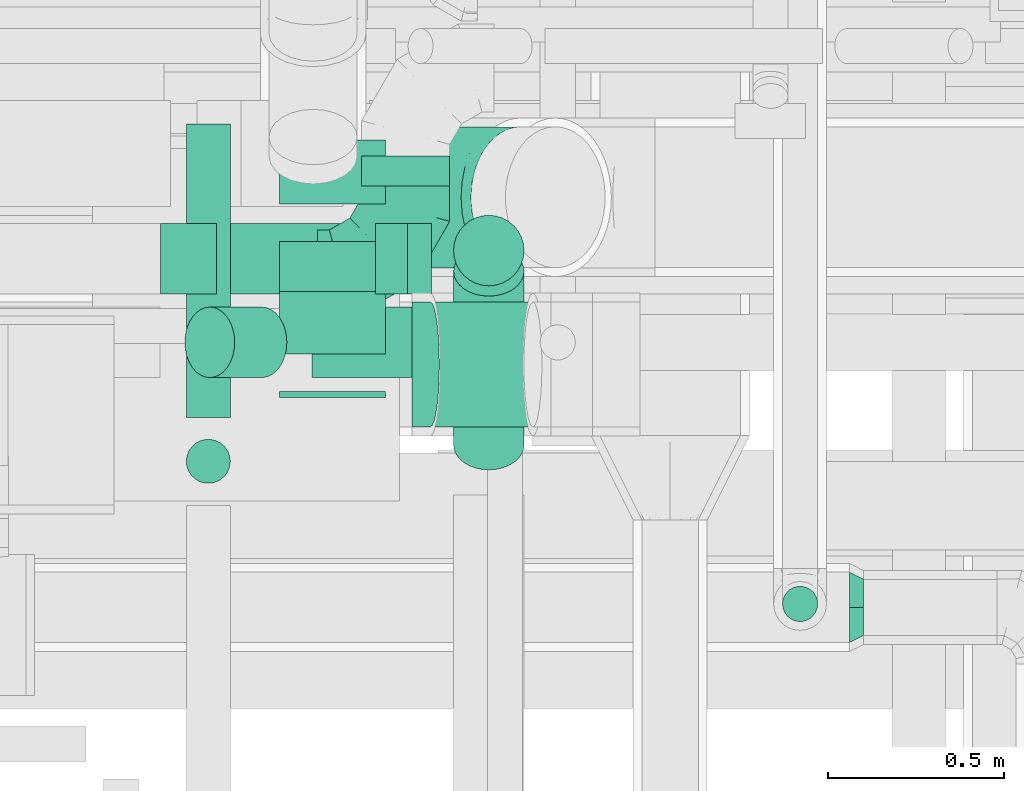
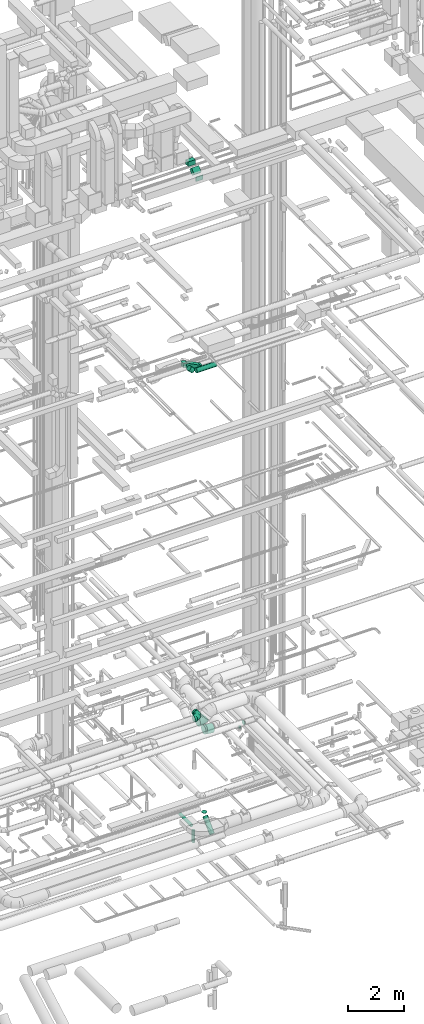
# One storey, part 253 of 337: 13 flow segments, 6 flow fittings.
"""IFC2X3 building model written with IfcOpenShell, lengths in millimetres."""

from ifc_helpers import new_model, entity, si_unit, converted_unit, derived_unit, direction, frame, frame_2d, origin, origin_2d_with_axis, place, context, subcontext, project, spatial, polyline, circle_curve, parameter, trimmed, segment, composite_curve, rectangle, circle, outline, extrude, faceted_brep, source, transform, mapped, material, type_object, type_shapes, element, save


model = new_model("IFC2X3")

# Units and contexts
model_context = context("Model", 3, precision=0.01, world=origin(), true_north=direction((6.12303176911189e-17, 1.0)))
body_context = subcontext(model_context, "Body", "Model", "MODEL_VIEW")
ifc_project = project(units=[si_unit("LENGTHUNIT", "METRE", prefix="MILLI"), si_unit("AREAUNIT", "SQUARE_METRE"), si_unit("VOLUMEUNIT", "CUBIC_METRE"), converted_unit("PLANEANGLEUNIT", "DEGREE", entity("IfcRatioMeasure", 0.0174532925199433), si_unit("PLANEANGLEUNIT", "RADIAN"), dimensions=[0, 0, 0, 0, 0, 0, 0]), si_unit("MASSUNIT", "GRAM", prefix="KILO"), derived_unit("MASSDENSITYUNIT", [(si_unit("MASSUNIT", "GRAM", prefix="KILO"), 1), (si_unit("LENGTHUNIT", "METRE"), -3)]), derived_unit("MOMENTOFINERTIAUNIT", [(si_unit("LENGTHUNIT", "METRE"), 4)]), si_unit("TIMEUNIT", "SECOND"), si_unit("FREQUENCYUNIT", "HERTZ"), si_unit("THERMODYNAMICTEMPERATUREUNIT", "DEGREE_CELSIUS"), derived_unit("THERMALTRANSMITTANCEUNIT", [(si_unit("MASSUNIT", "GRAM", prefix="KILO"), 1), (si_unit("THERMODYNAMICTEMPERATUREUNIT", "KELVIN"), -1), (si_unit("TIMEUNIT", "SECOND"), -3)]), derived_unit("VOLUMETRICFLOWRATEUNIT", [(si_unit("LENGTHUNIT", "METRE"), 3), (si_unit("TIMEUNIT", "SECOND"), -1)]), derived_unit("MASSFLOWRATEUNIT", [(si_unit("MASSUNIT", "GRAM", prefix="KILO"), 1), (si_unit("TIMEUNIT", "SECOND"), -1)]), derived_unit("ROTATIONALFREQUENCYUNIT", [(si_unit("TIMEUNIT", "SECOND"), -1)]), si_unit("ELECTRICCURRENTUNIT", "AMPERE"), si_unit("ELECTRICVOLTAGEUNIT", "VOLT"), si_unit("POWERUNIT", "WATT"), si_unit("FORCEUNIT", "NEWTON", prefix="KILO"), si_unit("ILLUMINANCEUNIT", "LUX"), si_unit("LUMINOUSFLUXUNIT", "LUMEN"), si_unit("LUMINOUSINTENSITYUNIT", "CANDELA"), derived_unit("USERDEFINED", [(si_unit("MASSUNIT", "GRAM", prefix="KILO"), -1), (si_unit("LENGTHUNIT", "METRE"), -2), (si_unit("TIMEUNIT", "SECOND"), 3), (si_unit("LUMINOUSFLUXUNIT", "LUMEN"), 1)]), derived_unit("LINEARVELOCITYUNIT", [(si_unit("LENGTHUNIT", "METRE"), 1), (si_unit("TIMEUNIT", "SECOND"), -1)]), si_unit("PRESSUREUNIT", "PASCAL"), derived_unit("USERDEFINED", [(si_unit("LENGTHUNIT", "METRE"), -2), (si_unit("MASSUNIT", "GRAM", prefix="KILO"), 1), (si_unit("TIMEUNIT", "SECOND"), -2)]), derived_unit("LINEARFORCEUNIT", [(si_unit("MASSUNIT", "GRAM", prefix="KILO"), 1), (si_unit("LENGTHUNIT", "METRE"), 1), (si_unit("TIMEUNIT", "SECOND"), -2), (si_unit("LENGTHUNIT", "METRE"), -1)]), derived_unit("PLANARFORCEUNIT", [(si_unit("MASSUNIT", "GRAM", prefix="KILO"), 1), (si_unit("LENGTHUNIT", "METRE"), 1), (si_unit("TIMEUNIT", "SECOND"), -2), (si_unit("LENGTHUNIT", "METRE"), -2)])], contexts=[model_context])

# Site, building, storey
site_placement = place(None, origin())
site = spatial("IfcSite", under=ifc_project, at=site_placement, CompositionType="ELEMENT")
building_placement = place(site_placement, origin())
building = spatial("IfcBuilding", under=site, at=building_placement, CompositionType="ELEMENT")
storey_placement = place(building_placement, origin())
storey = spatial("IfcBuildingStorey", under=building, at=storey_placement, CompositionType="ELEMENT", Elevation=0.0)

# Flow segments
duct_segment_type_1 = type_object("IfcDuctSegmentType", PredefinedType="NOTDEFINED")
flow_segment_1_placement = place(storey_placement, frame((63270.76, 9475.53, 18708.09)))
element("IfcFlowSegment", 1, at=flow_segment_1_placement, inside=storey, type_object=duct_segment_type_1, context=body_context, shape_type="SweptSolid", body=[
    extrude(rectangle(XDim=200.000000000004, YDim=200.0, at=origin_2d_with_axis()), frame((45.37, 100.0, 364.71), z_axis=(0.891177233196398, 0.0, -0.453655308612622), x_axis=(0.453655308612622, 0.0, 0.891177233196398)), (0.0, 0.0, 1.0), 607.484606409756),
])
flow_segment_2_placement = place(storey_placement, frame((63540.02, 9182.41, 27200.0)))
element("IfcFlowSegment", 2, at=flow_segment_2_placement, inside=storey, type_object=duct_segment_type_1, context=body_context, shape_type="SweptSolid", body=[
    extrude(rectangle(XDim=16.4306781186568, YDim=300.000000000001, at=origin_2d_with_axis()), frame((150.0, 8.22, 0.0), z_axis=(0.0, 0.0, 1.0), x_axis=(0.0, 1.0, 0.0)), (0.0, 0.0, 1.0), 199.999999999998),
])
flow_segment_3_placement = place(storey_placement, frame((63540.02, 9730.94, 27525.0)))
element("IfcFlowSegment", 3, at=flow_segment_3_placement, inside=storey, type_object=duct_segment_type_1, context=body_context, shape_type="SweptSolid", body=[
    extrude(rectangle(XDim=181.462540694988, YDim=300.000000000001, at=origin_2d_with_axis()), frame((150.0, 90.73, 0.0), z_axis=(0.0, 0.0, 1.0), x_axis=(0.0, 1.0, 0.0)), (0.0, 0.0, 1.0), 199.999999999998),
])
flow_segment_4_placement = place(storey_placement, frame((63540.02, 9304.9, 27302.51)))
element("IfcFlowSegment", 4, at=flow_segment_4_placement, inside=storey, type_object=duct_segment_type_1, context=body_context, shape_type="SweptSolid", body=[
    extrude(rectangle(XDim=252.512626584746, YDim=200.000000000001, at=origin_2d_with_axis()), frame((0.0, 159.99, 159.99), z_axis=(1.0, 0.0, 0.0), x_axis=(0.0, 0.707106781186548, 0.707106781186548)), (0.0, 0.0, 1.0), 300.000000000001),
])
duct_segment_type_2 = type_object("IfcDuctSegmentType", PredefinedType="NOTDEFINED")
flow_segment_5_placement = place(storey_placement, frame((63274.01, 9126.07, -849.1)))
element("IfcFlowSegment", 5, at=flow_segment_5_placement, inside=storey, type_object=duct_segment_type_2, context=body_context, shape_type="SweptSolid", body=[
    extrude(circle(Radius=62.5, at=origin_2d_with_axis()), frame((64.1, 0.0, 64.1), z_axis=(0.0, 1.0, 0.0), x_axis=(-1.0, 0.0, 0.0)), (0.0, 0.0, 1.0), 832.512489999981),
])
flow_segment_6_placement = place(storey_placement, frame((63274.01, 8936.97, -1425.0)))
element("IfcFlowSegment", 6, at=flow_segment_6_placement, inside=storey, type_object=duct_segment_type_2, context=body_context, shape_type="SweptSolid", body=[
    extrude(circle(Radius=62.5, at=origin_2d_with_axis()), frame((64.1, 64.1, 0.0), z_axis=(0.0, 0.0, 1.0), x_axis=(-1.0, 0.0, 0.0)), (0.0, 0.0, 1.0), 514.999994350737),
])
flow_segment_7_placement = place(storey_placement, frame((63631.55, 9236.98, 18733.4)))
element("IfcFlowSegment", 7, at=flow_segment_7_placement, inside=storey, type_object=duct_segment_type_2, context=body_context, shape_type="SweptSolid", body=[
    extrude(circle(Radius=100.0, at=origin_2d_with_axis()), frame((0.0, 101.6, 101.6), z_axis=(1.0, 0.0, 0.0), x_axis=(0.0, -1.0, 0.0)), (0.0, 0.0, 1.0), 820.417518557431),
])
flow_segment_8_placement = place(storey_placement, frame((63269.98, 9236.98, 18821.27)))
element("IfcFlowSegment", 8, at=flow_segment_8_placement, inside=storey, type_object=duct_segment_type_2, context=body_context, shape_type="SweptSolid", body=[
    extrude(circle(Radius=100.0, at=origin_2d_with_axis()), frame((220.15, 101.6, 72.31), z_axis=(-0.707106781186538, 0.0, 0.707106781186557), x_axis=(0.0, -1.0, 0.0)), (0.0, 0.0, 1.0), 209.081169079635),
])
flow_segment_9_placement = place(storey_placement, frame((63771.37, 9782.5, 3393.4)))
element("IfcFlowSegment", 9, at=flow_segment_9_placement, inside=storey, type_object=duct_segment_type_2, context=body_context, shape_type="SweptSolid", body=[
    extrude(circle(Radius=125.0, at=origin_2d_with_axis()), frame((126.6, 0.0, 126.6), z_axis=(0.0, 1.0, 0.0), x_axis=(-1.0, 0.0, 0.0)), (0.0, 0.0, 1.0), 84.1851551895519),
])
flow_segment_10_placement = place(storey_placement, frame((63940.55, 9096.79, 2876.5)))
element("IfcFlowSegment", 10, at=flow_segment_10_placement, inside=storey, type_object=duct_segment_type_2, context=body_context, shape_type="SweptSolid", body=[
    extrude(circle(Radius=177.5, at=origin_2d_with_axis()), frame((27.27, 179.1, 219.76), z_axis=(0.989486103669442, 0.0, -0.144627973245376), x_axis=(0.0, 1.0, 0.0)), (0.0, 0.0, 1.0), 294.10003462758),
])
flow_segment_11_placement = place(storey_placement, frame((64965.15, 8545.07, 3200.0)))
element("IfcFlowSegment", 11, at=flow_segment_11_placement, inside=storey, type_object=duct_segment_type_2, context=body_context, shape_type="SweptSolid", body=[
    extrude(circle(Radius=50.0, at=origin_2d_with_axis()), frame((51.6, 51.6, 0.0)), (0.0, 0.0, 1.0), 80.501256289344),
])
flow_segment_12_placement = place(storey_placement, frame((64032.19, 9497.39, -757.16)))
element("IfcFlowSegment", 12, at=flow_segment_12_placement, inside=storey, type_object=duct_segment_type_2, context=body_context, shape_type="SweptSolid", body=[
    extrude(circle(Radius=100.0, at=origin_2d_with_axis()), frame((101.6, 101.6, 0.0), z_axis=(0.0, 0.0, 1.0), x_axis=(0.0, 1.0, 0.0)), (0.0, 0.0, 1.0), 7.15728752538508),
])
flow_segment_13_placement = place(storey_placement, frame((64032.19, 8975.26, -1463.73)))
element("IfcFlowSegment", 13, at=flow_segment_13_placement, inside=storey, type_object=duct_segment_type_2, context=body_context, shape_type="SweptSolid", body=[
    extrude(circle(Radius=100.0, at=origin_2d_with_axis()), frame((101.6, 72.31, 72.31), z_axis=(0.0, 0.707106781186548, 0.707106781186547), x_axis=(1.0, 0.0, 0.0)), (0.0, 0.0, 1.0), 696.984848098373),
])

# Flow fittings
ifc_material = material()
duct_fitting_type_1 = type_object("IfcDuctFittingType", PredefinedType="NOTDEFINED", material=ifc_material)
shared_shape_1 = source(origin(), body_context, "Body", "Brep", [
    faceted_brep([(-250.0, 0.0, -125.0), (-250.0, -32.35, -120.74), (-250.0, -62.5, -108.25), (-250.0, -88.39, -88.39), (-250.0, -108.25, -62.5), (-250.0, -120.74, -32.35), (-250.0, -125.0, 0.0), (-250.0, -120.74, 32.35), (-250.0, -108.25, 62.5), (-250.0, -88.39, 88.39), (-250.0, -62.5, 108.25), (-250.0, -32.35, 120.74), (-250.0, 0.0, 125.0), (-250.0, 32.35, 120.74), (-250.0, 62.5, 108.25), (-250.0, 88.39, 88.39), (-250.0, 108.25, 62.5), (-250.0, 120.74, 32.35), (-250.0, 125.0, 0.0), (-250.0, 120.74, -32.35), (-250.0, 108.25, -62.5), (-250.0, 88.39, -88.39), (-250.0, 62.5, -108.25), (-250.0, 32.35, -120.74), (-191.68, 32.35, 120.74), (-199.76, 62.5, 108.25), (-183.01, 0.0, 125.0), (-206.7, 88.39, 88.39), (-215.37, 120.74, 32.35), (-216.51, 125.0, 0.0), (-212.02, 108.25, 62.5), (-212.02, 108.25, -62.5), (-206.7, 88.39, -88.39), (-215.37, 120.74, -32.35), (-191.68, 32.35, -120.74), (-183.01, 0.0, -125.0), (-199.76, 62.5, -108.25), (-174.34, -32.35, -120.74), (-166.27, -62.5, -108.25), (-159.33, -88.39, -88.39), (-154.01, -108.25, -62.5), (-150.66, -120.74, -32.35), (-149.52, -125.0, 0.0), (-150.66, -120.74, 32.35), (-154.01, -108.25, 62.5), (-159.33, -88.39, 88.39), (-166.27, -62.5, 108.25), (-174.34, -32.35, 120.74), (-90.67, 90.67, 120.74), (-112.74, 112.74, 108.25), (-66.99, 66.99, 125.0), (-131.69, 131.69, 88.39), (-146.23, 146.23, 62.5), (-155.38, 155.38, 32.35), (-158.49, 158.49, 0.0), (-155.38, 155.38, -32.35), (-146.23, 146.23, -62.5), (-131.69, 131.69, -88.39), (-90.67, 90.67, -120.74), (-66.99, 66.99, -125.0), (-112.74, 112.74, -108.25), (-43.3, 43.3, -120.74), (-21.23, 21.23, -108.25), (-2.28, 2.28, -88.39), (12.26, -12.26, -62.5), (21.4, -21.4, -32.35), (24.52, -24.52, 0.0), (21.4, -21.4, 32.35), (12.26, -12.26, 62.5), (-2.28, 2.28, 88.39), (-21.23, 21.23, 108.25), (-43.3, 43.3, 120.74), (-32.35, 191.68, 120.74), (-62.5, 199.76, 108.25), (0.0, 183.01, 125.0), (-88.39, 206.7, 88.39), (-108.25, 212.02, 62.5), (-120.74, 215.37, 32.35), (-125.0, 216.51, 0.0), (-120.74, 215.37, -32.35), (-108.25, 212.02, -62.5), (-88.39, 206.7, -88.39), (-32.35, 191.68, -120.74), (0.0, 183.01, -125.0), (-62.5, 199.76, -108.25), (32.35, 174.34, -120.74), (62.5, 166.27, -108.25), (88.39, 159.33, -88.39), (108.25, 154.01, -62.5), (120.74, 150.66, -32.35), (125.0, 149.52, 0.0), (120.74, 150.66, 32.35), (108.25, 154.01, 62.5), (88.39, 159.33, 88.39), (62.5, 166.27, 108.25), (32.35, 174.34, 120.74), (-32.35, 250.0, -120.74), (-62.5, 250.0, -108.25), (-88.39, 250.0, -88.39), (-108.25, 250.0, -62.5), (-120.74, 250.0, -32.35), (-125.0, 250.0, 0.0), (-120.74, 250.0, 32.35), (-108.25, 250.0, 62.5), (-88.39, 250.0, 88.39), (-62.5, 250.0, 108.25), (-32.35, 250.0, 120.74), (0.0, 250.0, 125.0), (32.35, 250.0, 120.74), (62.5, 250.0, 108.25), (88.39, 250.0, 88.39), (108.25, 250.0, 62.5), (120.74, 250.0, 32.35), (125.0, 250.0, 0.0), (120.74, 250.0, -32.35), (108.25, 250.0, -62.5), (88.39, 250.0, -88.39), (62.5, 250.0, -108.25), (32.35, 250.0, -120.74), (0.0, 250.0, -125.0)], [[[0, 1, 2, 3, 4, 5, 6, 7, 8, 9, 10, 11, 12, 13, 14, 15, 16, 17, 18, 19, 20, 21, 22, 23]], [[24, 25, 14, 13]], [[26, 24, 13, 12]], [[14, 25, 27, 15]], [[28, 29, 18, 17]], [[30, 28, 17, 16]], [[15, 27, 30, 16]], [[20, 31, 32, 21]], [[33, 31, 20, 19]], [[18, 29, 33, 19]], [[34, 35, 0, 23]], [[36, 34, 23, 22]], [[21, 32, 36, 22]], [[1, 0, 35, 37]], [[2, 1, 37, 38]], [[38, 39, 3, 2]], [[5, 4, 40, 41]], [[6, 5, 41, 42]], [[39, 40, 4, 3]], [[6, 42, 43, 7]], [[7, 43, 44, 8]], [[8, 44, 45, 9]], [[9, 45, 46, 10]], [[10, 46, 47, 11]], [[26, 12, 11, 47]], [[48, 49, 25, 24]], [[50, 48, 24, 26]], [[27, 25, 49, 51]], [[52, 53, 28, 30]], [[51, 52, 30, 27]], [[29, 28, 53, 54]], [[55, 56, 31, 33]], [[54, 55, 33, 29]], [[32, 31, 56, 57]], [[58, 59, 35, 34]], [[60, 58, 34, 36]], [[57, 60, 36, 32]], [[37, 35, 59, 61]], [[38, 37, 61, 62]], [[39, 38, 62, 63]], [[41, 40, 64, 65]], [[42, 41, 65, 66]], [[63, 64, 40, 39]], [[43, 42, 66, 67]], [[44, 43, 67, 68]], [[68, 69, 45, 44]], [[46, 45, 69, 70]], [[47, 46, 70, 71]], [[26, 47, 71, 50]], [[72, 73, 49, 48]], [[74, 72, 48, 50]], [[51, 49, 73, 75]], [[76, 77, 53, 52]], [[75, 76, 52, 51]], [[54, 53, 77, 78]], [[79, 80, 56, 55]], [[78, 79, 55, 54]], [[57, 56, 80, 81]], [[82, 83, 59, 58]], [[84, 82, 58, 60]], [[81, 84, 60, 57]], [[61, 59, 83, 85]], [[62, 61, 85, 86]], [[63, 62, 86, 87]], [[65, 64, 88, 89]], [[66, 65, 89, 90]], [[87, 88, 64, 63]], [[67, 66, 90, 91]], [[68, 67, 91, 92]], [[92, 93, 69, 68]], [[70, 69, 93, 94]], [[71, 70, 94, 95]], [[50, 71, 95, 74]], [[96, 97, 98, 99, 100, 101, 102, 103, 104, 105, 106, 107, 108, 109, 110, 111, 112, 113, 114, 115, 116, 117, 118, 119]], [[72, 74, 107, 106]], [[73, 72, 106, 105]], [[75, 73, 105, 104]], [[77, 76, 103, 102]], [[78, 77, 102, 101]], [[75, 104, 103, 76]], [[78, 101, 100, 79]], [[79, 100, 99, 80]], [[80, 99, 98, 81]], [[84, 97, 96, 82]], [[82, 96, 119, 83]], [[84, 81, 98, 97]], [[83, 119, 118, 85]], [[85, 118, 117, 86]], [[116, 87, 86, 117]], [[88, 115, 114, 89]], [[89, 114, 113, 90]], [[115, 88, 87, 116]], [[91, 90, 113, 112]], [[92, 91, 112, 111]], [[111, 110, 93, 92]], [[95, 94, 109, 108]], [[74, 95, 108, 107]], [[110, 109, 94, 93]]]),
])
type_shapes(duct_fitting_type_1, [shared_shape_1])
flow_fitting_1_placement = place(storey_placement, frame((63897.96, 9532.5, 3520.0)))
element("IfcFlowFitting", 14, at=flow_fitting_1_placement, inside=storey, type_object=duct_fitting_type_1, material=ifc_material, context=body_context, shape_type="MappedRepresentation", body=[
    mapped(shared_shape_1, transform((0.0, 0.0, 0.0), scale=1.0)),
])
duct_fitting_type_2 = type_object("IfcDuctFittingType", PredefinedType="NOTDEFINED", material=ifc_material)
shared_shape_2 = source(origin(), body_context, "Body", "Brep", [
    faceted_brep([(40.0, -73.91, 30.61), (40.0, -76.96, 15.31), (40.0, -80.0, 0.0), (40.0, -76.96, -15.31), (40.0, -73.91, -30.61), (40.0, -65.24, -43.59), (40.0, -56.57, -56.57), (40.0, -43.59, -65.24), (40.0, -30.61, -73.91), (40.0, -15.31, -76.96), (40.0, 0.0, -80.0), (40.0, 15.31, -76.96), (40.0, 30.61, -73.91), (40.0, 43.59, -65.24), (40.0, 56.57, -56.57), (40.0, 65.24, -43.59), (40.0, 73.91, -30.61), (40.0, 76.96, -15.31), (40.0, 80.0, 0.0), (40.0, 76.96, 15.31), (40.0, 73.91, 30.61), (40.0, 65.24, 43.59), (40.0, 56.57, 56.57), (40.0, 43.59, 65.24), (40.0, 30.61, 73.91), (40.0, 15.31, 76.96), (40.0, 0.0, 80.0), (40.0, -15.31, 76.96), (40.0, -30.61, 73.91), (40.0, -43.59, 65.24), (40.0, -56.57, 56.57), (40.0, -65.24, 43.59), (0.0, -100.0, 0.0), (0.0, -95.11, 30.9), (0.0, -80.9, 58.78), (0.0, -58.78, 80.9), (0.0, -30.9, 95.11), (0.0, 0.0, 100.0), (0.0, 30.9, 95.11), (0.0, 58.78, 80.9), (0.0, 80.9, 58.78), (0.0, 95.11, 30.9), (0.0, 100.0, 0.0), (0.0, 95.11, -30.9), (0.0, 80.9, -58.78), (0.0, 58.78, -80.9), (0.0, 30.9, -95.11), (0.0, 0.0, -100.0), (0.0, -30.9, -95.11), (0.0, -58.78, -80.9), (0.0, -80.9, -58.78), (0.0, -95.11, -30.9)], [[[0, 1, 2, 3, 4, 5, 6, 7, 8, 9, 10, 11, 12, 13, 14, 15, 16, 17, 18, 19, 20, 21, 22, 23, 24, 25, 26, 27, 28, 29, 30, 31]], [[32, 33, 34, 35, 36, 37, 38, 39, 40, 41, 42, 43, 44, 45, 46, 47, 48, 49, 50, 51]], [[37, 25, 38]], [[25, 24, 38]], [[24, 39, 38]], [[41, 20, 19]], [[25, 37, 26]], [[39, 24, 23, 22]], [[42, 19, 18]], [[20, 40, 22, 21]], [[41, 40, 20]], [[42, 41, 19]], [[22, 40, 39]], [[32, 1, 33]], [[1, 0, 33]], [[0, 34, 33]], [[36, 28, 27]], [[1, 32, 2]], [[34, 0, 31, 30]], [[37, 27, 26]], [[28, 35, 30, 29]], [[36, 35, 28]], [[37, 36, 27]], [[30, 35, 34]], [[47, 9, 48]], [[9, 8, 48]], [[8, 49, 48]], [[51, 4, 3]], [[9, 47, 10]], [[49, 8, 7, 6]], [[32, 3, 2]], [[4, 50, 6, 5]], [[51, 50, 4]], [[32, 51, 3]], [[6, 50, 49]], [[42, 17, 43]], [[17, 16, 43]], [[16, 44, 43]], [[46, 12, 11]], [[17, 42, 18]], [[44, 16, 15, 14]], [[47, 11, 10]], [[12, 45, 14, 13]], [[46, 45, 12]], [[47, 46, 11]], [[14, 45, 44]]]),
])
type_shapes(duct_fitting_type_2, [shared_shape_2])
flow_fitting_2_placement = place(storey_placement, frame((65156.4, 8586.67, 3400.0)))
element("IfcFlowFitting", 15, at=flow_fitting_2_placement, inside=storey, type_object=duct_fitting_type_2, material=ifc_material, context=body_context, shape_type="MappedRepresentation", body=[
    mapped(shared_shape_2, transform((0.0, 0.0, 0.0), scale=1.0)),
])
duct_fitting_type_3 = type_object("IfcDuctFittingType", PredefinedType="NOTDEFINED", material=ifc_material)
shared_shape_3 = source(origin(), body_context, "Body", "Brep", [
    faceted_brep([(-165.69, 0.0, -200.0), (-165.69, -44.5, -194.99), (-165.69, -86.78, -180.19), (-165.69, -124.7, -156.37), (-165.69, -156.37, -124.7), (-165.69, -180.19, -86.78), (-165.69, -194.99, -44.5), (-165.69, -200.0, 0.0), (-165.69, -194.99, 44.5), (-165.69, -180.19, 86.78), (-165.69, -156.37, 124.7), (-165.69, -124.7, 156.37), (-165.69, -86.78, 180.19), (-165.69, -44.5, 194.99), (-165.69, 0.0, 200.0), (-165.69, 44.5, 194.99), (-165.69, 86.78, 180.19), (-165.69, 124.7, 156.37), (-165.69, 156.37, 124.7), (-165.69, 180.19, 86.78), (-165.69, 194.99, 44.5), (-165.69, 200.0, 0.0), (-165.69, 194.99, -44.5), (-165.69, 180.19, -86.78), (-165.69, 156.37, -124.7), (-165.69, 124.7, -156.37), (-165.69, 86.78, -180.19), (-165.69, 44.5, -194.99), (-86.12, 0.0, 200.0), (-94.97, 44.5, 194.99), (-103.38, 86.78, 180.19), (-110.92, 124.7, 156.37), (-117.22, 156.37, 124.7), (-121.96, 180.19, 86.78), (-124.91, 194.99, 44.5), (-125.9, 200.0, 0.0), (-124.91, 194.99, -44.5), (-121.96, 180.19, -86.78), (-117.22, 156.37, -124.7), (-110.92, 124.7, -156.37), (-103.38, 86.78, -180.19), (-94.97, 44.5, -194.99), (-86.12, 0.0, -200.0), (-77.27, -44.5, -194.99), (-68.86, -86.78, -180.19), (-61.32, -124.7, -156.37), (-55.02, -156.37, -124.7), (-50.28, -180.19, -86.78), (-47.34, -194.99, -44.5), (-46.34, -200.0, 0.0), (-47.34, -194.99, 44.5), (-50.28, -180.19, 86.78), (-55.02, -156.37, 124.7), (-61.32, -124.7, 156.37), (-68.86, -86.78, 180.19), (-77.27, -44.5, 194.99), (60.9, 60.9, 200.0), (35.69, 98.63, 194.99), (11.74, 134.46, 180.19), (-9.74, 166.61, 156.37), (-27.68, 193.46, 124.7), (-41.18, 213.66, 86.78), (-49.55, 226.2, 44.5), (-52.39, 230.45, 0.0), (-49.55, 226.2, -44.5), (-41.18, 213.66, -86.78), (-27.68, 193.46, -124.7), (-9.74, 166.61, -156.37), (11.74, 134.46, -180.19), (35.69, 98.63, -194.99), (60.9, 60.9, -200.0), (86.11, 23.17, -194.99), (110.05, -12.67, -180.19), (131.53, -44.82, -156.37), (149.47, -71.66, -124.7), (162.97, -91.86, -86.78), (171.35, -104.4, -44.5), (174.19, -108.66, 0.0), (171.35, -104.4, 44.5), (162.97, -91.86, 86.78), (149.47, -71.66, 124.7), (131.53, -44.82, 156.37), (110.05, -12.67, 180.19), (86.11, 23.17, 194.99), (117.16, 117.16, 200.0), (85.69, 148.63, 194.99), (55.8, 178.52, 180.19), (28.98, 205.33, 156.37), (6.59, 227.72, 124.7), (-10.26, 244.57, 86.78), (-20.72, 255.03, 44.5), (-24.26, 258.58, 0.0), (-20.72, 255.03, -44.5), (-10.26, 244.57, -86.78), (6.59, 227.72, -124.7), (28.98, 205.33, -156.37), (55.8, 178.52, -180.19), (85.69, 148.63, -194.99), (117.16, 117.16, -200.0), (148.63, 85.69, -194.99), (178.52, 55.8, -180.19), (205.33, 28.98, -156.37), (227.72, 6.59, -124.7), (244.57, -10.26, -86.78), (255.03, -20.72, -44.5), (258.58, -24.26, 0.0), (255.03, -20.72, 44.5), (244.57, -10.26, 86.78), (227.72, 6.59, 124.7), (205.33, 28.98, 156.37), (178.52, 55.8, 180.19), (148.63, 85.69, 194.99)], [[[0, 1, 2, 3, 4, 5, 6, 7, 8, 9, 10, 11, 12, 13, 14, 15, 16, 17, 18, 19, 20, 21, 22, 23, 24, 25, 26, 27]], [[28, 29, 15, 14]], [[30, 31, 17, 16]], [[29, 30, 16, 15]], [[31, 32, 18, 17]], [[32, 33, 19, 18]], [[34, 35, 21, 20]], [[33, 34, 20, 19]], [[35, 36, 22, 21]], [[37, 38, 24, 23]], [[36, 37, 23, 22]], [[38, 39, 25, 24]], [[39, 40, 26, 25]], [[41, 42, 0, 27]], [[40, 41, 27, 26]], [[1, 0, 42, 43]], [[43, 44, 2, 1]], [[45, 3, 2, 44]], [[45, 46, 4, 3]], [[5, 4, 46, 47]], [[47, 48, 6, 5]], [[49, 7, 6, 48]], [[7, 49, 50, 8]], [[8, 50, 51, 9]], [[9, 51, 52, 10]], [[52, 53, 11, 10]], [[11, 53, 54, 12]], [[12, 54, 55, 13]], [[13, 55, 28, 14]], [[56, 57, 29, 28]], [[58, 59, 31, 30]], [[57, 58, 30, 29]], [[59, 60, 32, 31]], [[60, 61, 33, 32]], [[62, 63, 35, 34]], [[61, 62, 34, 33]], [[63, 64, 36, 35]], [[65, 66, 38, 37]], [[64, 65, 37, 36]], [[66, 67, 39, 38]], [[67, 68, 40, 39]], [[69, 70, 42, 41]], [[68, 69, 41, 40]], [[43, 42, 70, 71]], [[71, 72, 44, 43]], [[73, 45, 44, 72]], [[73, 74, 46, 45]], [[47, 46, 74, 75]], [[75, 76, 48, 47]], [[77, 49, 48, 76]], [[50, 49, 77, 78]], [[51, 50, 78, 79]], [[52, 51, 79, 80]], [[80, 81, 53, 52]], [[54, 53, 81, 82]], [[55, 54, 82, 83]], [[28, 55, 83, 56]], [[57, 56, 84, 85]], [[85, 86, 58, 57]], [[87, 59, 58, 86]], [[87, 88, 60, 59]], [[88, 89, 61, 60]], [[90, 91, 63, 62]], [[89, 90, 62, 61]], [[63, 91, 92, 64]], [[92, 93, 65, 64]], [[94, 66, 65, 93]], [[94, 95, 67, 66]], [[67, 95, 96, 68]], [[68, 96, 97, 69]], [[69, 97, 98, 70]], [[98, 99, 71, 70]], [[99, 100, 72, 71]], [[72, 100, 101, 73]], [[101, 102, 74, 73]], [[74, 102, 103, 75]], [[75, 103, 104, 76]], [[76, 104, 105, 77]], [[78, 77, 105, 106]], [[79, 78, 106, 107]], [[80, 79, 107, 108]], [[108, 109, 81, 80]], [[82, 81, 109, 110]], [[83, 82, 110, 111]], [[56, 83, 111, 84]], [[90, 89, 88, 87, 86, 85, 84, 111, 110, 109, 108, 107, 106, 105, 104, 103, 102, 101, 100, 99, 98, 97, 96, 95, 94, 93, 92, 91]]]),
])
type_shapes(duct_fitting_type_3, [shared_shape_3])
flow_fitting_3_placement = place(storey_placement, frame((64107.51, 9750.0, 3168.04), z_axis=(0.0, 1.0, 0.0), x_axis=(-0.707106759953317, 0.0, -0.707106802419777)))
element("IfcFlowFitting", 16, at=flow_fitting_3_placement, inside=storey, type_object=duct_fitting_type_3, material=ifc_material, context=body_context, shape_type="MappedRepresentation", body=[
    mapped(shared_shape_3, transform((0.0, 0.0, 0.0), scale=1.0)),
])
duct_fitting_type_4 = type_object("IfcDuctFittingType", PredefinedType="NOTDEFINED", material=ifc_material)
shared_shape_4 = source(origin(), body_context, "Body", "Brep", [
    faceted_brep([(-25.81, 0.0, -177.5), (-25.81, -45.94, -171.45), (-25.81, -88.75, -153.72), (-25.81, -125.51, -125.51), (-25.81, -153.72, -88.75), (-25.81, -171.45, -45.94), (-25.81, -177.5, 0.0), (-25.81, -171.45, 45.94), (-25.81, -153.72, 88.75), (-25.81, -125.51, 125.51), (-25.81, -88.75, 153.72), (-25.81, -45.94, 171.45), (-25.81, 0.0, 177.5), (-25.81, 45.94, 171.45), (-25.81, 88.75, 153.72), (-25.81, 125.51, 125.51), (-25.81, 153.72, 88.75), (-25.81, 171.45, 45.94), (-25.81, 177.5, 0.0), (-25.81, 171.45, -45.94), (-25.81, 153.72, -88.75), (-25.81, 125.51, -125.51), (-25.81, 88.75, -153.72), (-25.81, 45.94, -171.45), (-3.34, 45.94, 171.45), (-6.45, 88.75, 153.72), (0.0, 0.0, 177.5), (-9.12, 125.51, 125.51), (-12.46, 171.45, 45.94), (-12.9, 177.5, 0.0), (-11.17, 153.72, 88.75), (-11.17, 153.72, -88.75), (-9.12, 125.51, -125.51), (-12.46, 171.45, -45.94), (-3.34, 45.94, -171.45), (0.0, 0.0, -177.5), (-6.45, 88.75, -153.72), (3.34, -45.94, -171.45), (6.45, -88.75, -153.72), (9.12, -125.51, -125.51), (11.17, -153.72, -88.75), (12.46, -171.45, -45.94), (12.9, -177.5, 0.0), (12.46, -171.45, 45.94), (11.17, -153.72, 88.75), (9.12, -125.51, 125.51), (6.45, -88.75, 153.72), (3.34, -45.94, 171.45), (25.54, 3.73, 177.5), (18.89, 49.19, 171.45), (12.7, 91.55, 153.72), (7.38, 127.92, 125.51), (3.3, 155.84, 88.75), (0.74, 173.38, 45.94), (-0.14, 179.37, 0.0), (0.74, 173.38, -45.94), (3.3, 155.84, -88.75), (7.38, 127.92, -125.51), (12.7, 91.55, -153.72), (18.89, 49.19, -171.45), (25.54, 3.73, -177.5), (32.18, -41.72, -171.45), (38.37, -84.08, -153.72), (43.69, -120.46, -125.51), (50.33, -165.92, -45.94), (51.21, -171.9, 0.0), (47.77, -148.37, -88.75), (50.33, -165.92, 45.94), (47.77, -148.37, 88.75), (43.69, -120.46, 125.51), (38.37, -84.08, 153.72), (32.18, -41.72, 171.45)], [[[0, 1, 2, 3, 4, 5, 6, 7, 8, 9, 10, 11, 12, 13, 14, 15, 16, 17, 18, 19, 20, 21, 22, 23]], [[24, 25, 14, 13]], [[26, 24, 13, 12]], [[14, 25, 27, 15]], [[28, 29, 18, 17]], [[30, 28, 17, 16]], [[15, 27, 30, 16]], [[20, 31, 32, 21]], [[33, 31, 20, 19]], [[18, 29, 33, 19]], [[34, 35, 0, 23]], [[36, 34, 23, 22]], [[21, 32, 36, 22]], [[2, 1, 37, 38]], [[3, 2, 38, 39]], [[0, 35, 37, 1]], [[5, 4, 40, 41]], [[6, 5, 41, 42]], [[39, 40, 4, 3]], [[6, 42, 43, 7]], [[7, 43, 44, 8]], [[8, 44, 45, 9]], [[10, 46, 47, 11]], [[11, 47, 26, 12]], [[9, 45, 46, 10]], [[24, 26, 48, 49]], [[25, 24, 49, 50]], [[27, 25, 50, 51]], [[28, 30, 52, 53]], [[29, 28, 53, 54]], [[27, 51, 52, 30]], [[29, 54, 55, 33]], [[33, 55, 56, 31]], [[31, 56, 57, 32]], [[36, 58, 59, 34]], [[34, 59, 60, 35]], [[36, 32, 57, 58]], [[35, 60, 61, 37]], [[37, 61, 62, 38]], [[38, 62, 63, 39]], [[64, 65, 42, 41]], [[66, 64, 41, 40]], [[39, 63, 66, 40]], [[43, 42, 65, 67]], [[44, 43, 67, 68]], [[45, 44, 68, 69]], [[47, 46, 70, 71]], [[26, 47, 71, 48]], [[69, 70, 46, 45]], [[59, 58, 57, 56, 55, 54, 53, 52, 51, 50, 49, 48, 71, 70, 69, 68, 67, 65, 64, 66, 63, 62, 61, 60]]]),
])
type_shapes(duct_fitting_type_4, [shared_shape_4])
flow_fitting_4_placement = place(storey_placement, frame((63942.28, 9275.88, 3100.0), z_axis=(0.0, -1.0, 0.0), x_axis=(-0.989486103669435, 0.0, 0.14462797324543)))
element("IfcFlowFitting", 17, at=flow_fitting_4_placement, inside=storey, type_object=duct_fitting_type_4, material=ifc_material, context=body_context, shape_type="MappedRepresentation", body=[
    mapped(shared_shape_4, transform((0.0, 0.0, 0.0), scale=1.0)),
])
duct_fitting_type_5 = type_object("IfcDuctFittingType", PredefinedType="NOTDEFINED", material=ifc_material)
shared_shape_5 = source(origin(), body_context, "Body", "SweptSolid", [
    extrude(outline(composite_curve([segment(polyline([(-113.6, -56.71), (86.4, -56.71)]), True, "CONTINUOUS"), segment(trimmed(circle_curve(frame_2d((236.4, -56.71), x_axis=(-0.891177233196444, 0.453655308612534)), 150.0), [parameter(0.0)], [parameter(26.9784477480484)], True, "PARAMETER"), False, "CONTINUOUS"), segment(polyline([(102.72, 11.34), (-75.51, 102.07)]), True, "CONTINUOUS"), segment(trimmed(circle_curve(frame_2d((236.4, -56.71), x_axis=(-0.891177233196444, 0.453655308612534)), 350.0), [parameter(0.0)], [parameter(26.9784477480484)], True, "PARAMETER"), True, "CONTINUOUS")], self_intersect=False)), frame((-3.26, 13.6, -100.0), z_axis=(0.0, 0.0, 1.0), x_axis=(-0.453655308612534, 0.891177233196443, 0.0)), (0.0, 0.0, 1.0), 200.0),
])
type_shapes(duct_fitting_type_5, [shared_shape_5])
for number, where, z_axis, x_axis in (
    (18, (63910.94, 9575.53, 18770.0), (0.0, 1.0, 0.0), (-1.0, 0.0, 0.0)),
    (19, (63262.68, 9575.53, 19100.0), (0.0, -1.0, 0.0), (-0.891177233196414, 0.0, 0.45365530861259)),
):
    element("IfcFlowFitting", number, at=place(storey_placement, frame(where, z_axis=z_axis, x_axis=x_axis)), inside=storey, type_object=duct_fitting_type_5, material=ifc_material, context=body_context, shape_type="MappedRepresentation", body=[
        mapped(shared_shape_5, transform((0.0, 0.0, 0.0), scale=1.0)),
    ])

save(model, "model.ifc")
